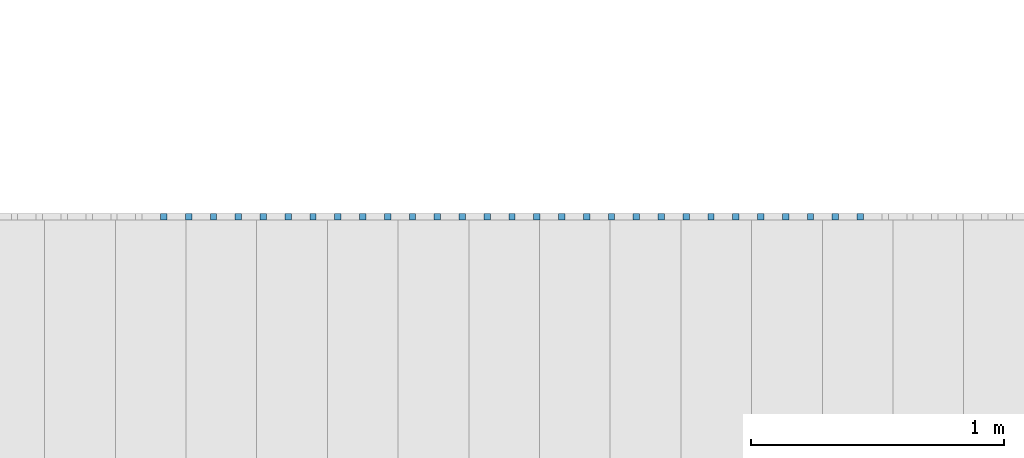
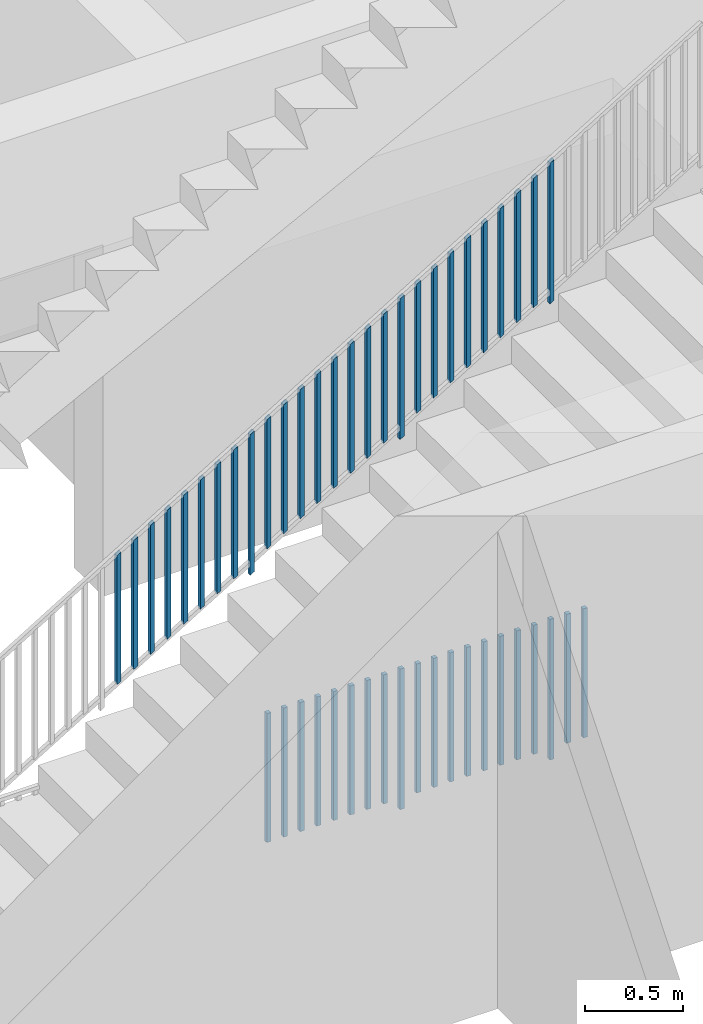
# One storey, part 21 of 23: 47 building element parts, 2 elements without a shape of their own.
"""IFC4 building model written with IfcOpenShell, lengths in metres."""

from ifc_helpers import new_model, entity, si_unit, converted_unit, derived_unit, direction, frame, origin_with_axes, place, context, subcontext, project, spatial, polygons, material, type_object, element, aggregate, save


model = new_model("IFC4")

# Units and contexts
model_context = context("Model", 3, precision=1e-05, world=origin_with_axes(), true_north=direction((0.0, 1.0)))
body_context = subcontext(model_context, "Body", "Model", "MODEL_VIEW")
ifc_project = project(units=[si_unit("LENGTHUNIT", "METRE"), si_unit("AREAUNIT", "SQUARE_METRE"), si_unit("VOLUMEUNIT", "CUBIC_METRE"), converted_unit("PLANEANGLEUNIT", "DEGREE", entity("IfcPlaneAngleMeasure", 0.0174532925199), si_unit("PLANEANGLEUNIT", "RADIAN"), dimensions=[0, 0, 0, 0, 0, 0, 0]), converted_unit("TIMEUNIT", "Year", entity("IfcTimeMeasure", 31556926.0), si_unit("TIMEUNIT", "SECOND"), dimensions=[0, 0, 1, 0, 0, 0, 0]), si_unit("MASSUNIT", "GRAM", prefix="KILO"), si_unit("THERMODYNAMICTEMPERATUREUNIT", "DEGREE_CELSIUS"), si_unit("LUMINOUSINTENSITYUNIT", "LUMEN"), si_unit("ENERGYUNIT", "JOULE", prefix="MEGA"), derived_unit("THERMALCONDUCTANCEUNIT", [(si_unit("POWERUNIT", "WATT"), 1), (si_unit("LENGTHUNIT", "METRE"), -1), (si_unit("THERMODYNAMICTEMPERATUREUNIT", "KELVIN"), -1)]), derived_unit("SPECIFICHEATCAPACITYUNIT", [(si_unit("ENERGYUNIT", "JOULE"), 1), (si_unit("MASSUNIT", "GRAM", prefix="KILO"), -1), (si_unit("THERMODYNAMICTEMPERATUREUNIT", "KELVIN"), -1)]), derived_unit("MASSDENSITYUNIT", [(si_unit("MASSUNIT", "GRAM", prefix="KILO"), 1), (si_unit("VOLUMEUNIT", "CUBIC_METRE"), -1)])], contexts=[model_context])

# Site, building, storey, space
site_placement = place(None, origin_with_axes())
site = spatial("IfcSite", under=ifc_project, at=site_placement, CompositionType="ELEMENT")
building_placement = place(site_placement, origin_with_axes())
building = spatial("IfcBuilding", under=site, at=building_placement, CompositionType="ELEMENT")
storey_placement = place(building_placement, origin_with_axes())
storey = spatial("IfcBuildingStorey", under=building, at=storey_placement, Name="0. Geschoss", CompositionType="ELEMENT", Elevation=0.0)
space_placement = place(storey_placement, frame((-11.4421993804, 1.37118776896, 0.0), z_axis=(0.0, 0.0, 1.0), x_axis=(0.0, -1.0, 0.0)))
space = spatial("IfcSpace", under=storey, at=space_placement, CompositionType="ELEMENT", PredefinedType="INTERNAL")

# Railing, building element parts
railing_type = type_object("IfcRailingType", PredefinedType="NOTDEFINED")
railing_1_placement = place(space_placement, frame((1.5, 8.0, 0.0), z_axis=(0.0, 0.0, 1.0), x_axis=(0.0, 1.0, 0.0)))
railing_1 = element("IfcRailing", 1, at=railing_1_placement, inside=space, type_object=railing_type, PredefinedType="NOTDEFINED")
ifc_material = material()
building_element_part_1_placement = place(railing_1_placement, origin_with_axes())
building_element_part_1 = element("IfcBuildingElementPart", 2, at=building_element_part_1_placement, material=ifc_material, PredefinedType="NOTDEFINED", context=body_context, shape_type="Tessellation", body=[
    polygons([(1.93101851852, -0.9125, 0.07), (1.93101851852, -0.8875, 0.07), (1.93101851852, -0.8875, 0.8775), (1.93101851852, -0.9125, 0.8775), (1.90601851852, -0.9125, 0.07), (1.90601851852, -0.8875, 0.07), (1.90601851852, -0.8875, 0.8775), (1.90601851852, -0.9125, 0.8775)], [[[1, 2, 3, 4]], [[1, 5, 6, 2]], [[2, 6, 7, 3]], [[4, 3, 7, 8]], [[5, 1, 4, 8]], [[6, 5, 8, 7]]], closed=True),
])
building_element_part_2_placement = place(railing_1_placement, origin_with_axes())
building_element_part_2 = element("IfcBuildingElementPart", 3, at=building_element_part_2_placement, material=ifc_material, PredefinedType="NOTDEFINED", context=body_context, shape_type="Tessellation", body=[
    polygons([(2.02953703704, -0.9125, 0.07), (2.02953703704, -0.8875, 0.07), (2.02953703704, -0.8875, 0.8775), (2.02953703704, -0.9125, 0.8775), (2.00453703704, -0.9125, 0.07), (2.00453703704, -0.8875, 0.07), (2.00453703704, -0.8875, 0.8775), (2.00453703704, -0.9125, 0.8775)], [[[1, 2, 3, 4]], [[1, 5, 6, 2]], [[2, 6, 7, 3]], [[4, 3, 7, 8]], [[5, 1, 4, 8]], [[6, 5, 8, 7]]], closed=True),
])
building_element_part_3_placement = place(railing_1_placement, origin_with_axes())
building_element_part_3 = element("IfcBuildingElementPart", 4, at=building_element_part_3_placement, material=ifc_material, PredefinedType="NOTDEFINED", context=body_context, shape_type="Tessellation", body=[
    polygons([(2.12805555556, -0.9125, 0.07), (2.12805555556, -0.8875, 0.07), (2.12805555556, -0.8875, 0.8775), (2.12805555556, -0.9125, 0.8775), (2.10305555556, -0.9125, 0.07), (2.10305555556, -0.8875, 0.07), (2.10305555556, -0.8875, 0.8775), (2.10305555556, -0.9125, 0.8775)], [[[1, 2, 3, 4]], [[1, 5, 6, 2]], [[2, 6, 7, 3]], [[4, 3, 7, 8]], [[5, 1, 4, 8]], [[6, 5, 8, 7]]], closed=True),
])
building_element_part_4_placement = place(railing_1_placement, origin_with_axes())
building_element_part_4 = element("IfcBuildingElementPart", 5, at=building_element_part_4_placement, material=ifc_material, PredefinedType="NOTDEFINED", context=body_context, shape_type="Tessellation", body=[
    polygons([(2.22657407407, -0.9125, 0.07), (2.22657407407, -0.8875, 0.07), (2.22657407407, -0.8875, 0.8775), (2.22657407407, -0.9125, 0.8775), (2.20157407407, -0.9125, 0.07), (2.20157407407, -0.8875, 0.07), (2.20157407407, -0.8875, 0.8775), (2.20157407407, -0.9125, 0.8775)], [[[1, 2, 3, 4]], [[1, 5, 6, 2]], [[2, 6, 7, 3]], [[4, 3, 7, 8]], [[5, 1, 4, 8]], [[6, 5, 8, 7]]], closed=True),
])
building_element_part_5_placement = place(railing_1_placement, origin_with_axes())
building_element_part_5 = element("IfcBuildingElementPart", 6, at=building_element_part_5_placement, material=ifc_material, PredefinedType="NOTDEFINED", context=body_context, shape_type="Tessellation", body=[
    polygons([(2.32509259259, -0.9125, 0.07), (2.32509259259, -0.8875, 0.07), (2.32509259259, -0.8875, 0.8775), (2.32509259259, -0.9125, 0.8775), (2.30009259259, -0.9125, 0.07), (2.30009259259, -0.8875, 0.07), (2.30009259259, -0.8875, 0.8775), (2.30009259259, -0.9125, 0.8775)], [[[1, 2, 3, 4]], [[1, 5, 6, 2]], [[2, 6, 7, 3]], [[4, 3, 7, 8]], [[5, 1, 4, 8]], [[6, 5, 8, 7]]], closed=True),
])
building_element_part_6_placement = place(railing_1_placement, origin_with_axes())
building_element_part_6 = element("IfcBuildingElementPart", 7, at=building_element_part_6_placement, material=ifc_material, PredefinedType="NOTDEFINED", context=body_context, shape_type="Tessellation", body=[
    polygons([(2.42361111111, -0.9125, 0.07), (2.42361111111, -0.8875, 0.07), (2.42361111111, -0.8875, 0.8775), (2.42361111111, -0.9125, 0.8775), (2.39861111111, -0.9125, 0.07), (2.39861111111, -0.8875, 0.07), (2.39861111111, -0.8875, 0.8775), (2.39861111111, -0.9125, 0.8775)], [[[1, 2, 3, 4]], [[1, 5, 6, 2]], [[2, 6, 7, 3]], [[4, 3, 7, 8]], [[5, 1, 4, 8]], [[6, 5, 8, 7]]], closed=True),
])
building_element_part_7_placement = place(railing_1_placement, origin_with_axes())
building_element_part_7 = element("IfcBuildingElementPart", 8, at=building_element_part_7_placement, material=ifc_material, PredefinedType="NOTDEFINED", context=body_context, shape_type="Tessellation", body=[
    polygons([(2.52212962963, -0.9125, 0.07), (2.52212962963, -0.8875, 0.07), (2.52212962963, -0.8875, 0.8775), (2.52212962963, -0.9125, 0.8775), (2.49712962963, -0.9125, 0.07), (2.49712962963, -0.8875, 0.07), (2.49712962963, -0.8875, 0.8775), (2.49712962963, -0.9125, 0.8775)], [[[1, 2, 3, 4]], [[1, 5, 6, 2]], [[2, 6, 7, 3]], [[4, 3, 7, 8]], [[5, 1, 4, 8]], [[6, 5, 8, 7]]], closed=True),
])
building_element_part_8_placement = place(railing_1_placement, origin_with_axes())
building_element_part_8 = element("IfcBuildingElementPart", 9, at=building_element_part_8_placement, material=ifc_material, PredefinedType="NOTDEFINED", context=body_context, shape_type="Tessellation", body=[
    polygons([(2.62064814815, -0.9125, 0.07), (2.62064814815, -0.8875, 0.07), (2.62064814815, -0.8875, 0.8775), (2.62064814815, -0.9125, 0.8775), (2.59564814815, -0.9125, 0.07), (2.59564814815, -0.8875, 0.07), (2.59564814815, -0.8875, 0.8775), (2.59564814815, -0.9125, 0.8775)], [[[1, 2, 3, 4]], [[1, 5, 6, 2]], [[2, 6, 7, 3]], [[4, 3, 7, 8]], [[5, 1, 4, 8]], [[6, 5, 8, 7]]], closed=True),
])
building_element_part_9_placement = place(railing_1_placement, origin_with_axes())
building_element_part_9 = element("IfcBuildingElementPart", 10, at=building_element_part_9_placement, material=ifc_material, PredefinedType="NOTDEFINED", context=body_context, shape_type="Tessellation", body=[
    polygons([(2.71916666667, -0.9125, 0.0), (2.71916666667, -0.8875, 0.0), (2.71916666667, -0.8875, 0.88), (2.71916666667, -0.9125, 0.88), (2.69416666667, -0.9125, 0.0), (2.69416666667, -0.8875, 0.0), (2.69416666667, -0.8875, 0.88), (2.69416666667, -0.9125, 0.88)], [[[1, 2, 3, 4]], [[1, 5, 6, 2]], [[2, 6, 7, 3]], [[4, 3, 7, 8]], [[5, 1, 4, 8]], [[6, 5, 8, 7]]], closed=True),
])
building_element_part_10_placement = place(railing_1_placement, origin_with_axes())
building_element_part_10 = element("IfcBuildingElementPart", 11, at=building_element_part_10_placement, material=ifc_material, PredefinedType="NOTDEFINED", context=body_context, shape_type="Tessellation", body=[
    polygons([(2.81768518519, -0.9125, 0.07), (2.81768518519, -0.8875, 0.07), (2.81768518519, -0.8875, 0.8775), (2.81768518519, -0.9125, 0.8775), (2.79268518519, -0.9125, 0.07), (2.79268518519, -0.8875, 0.07), (2.79268518519, -0.8875, 0.8775), (2.79268518519, -0.9125, 0.8775)], [[[1, 2, 3, 4]], [[1, 5, 6, 2]], [[2, 6, 7, 3]], [[4, 3, 7, 8]], [[5, 1, 4, 8]], [[6, 5, 8, 7]]], closed=True),
])
building_element_part_11_placement = place(railing_1_placement, origin_with_axes())
building_element_part_11 = element("IfcBuildingElementPart", 12, at=building_element_part_11_placement, material=ifc_material, PredefinedType="NOTDEFINED", context=body_context, shape_type="Tessellation", body=[
    polygons([(2.9162037037, -0.9125, 0.07), (2.9162037037, -0.8875, 0.07), (2.9162037037, -0.8875, 0.8775), (2.9162037037, -0.9125, 0.8775), (2.8912037037, -0.9125, 0.07), (2.8912037037, -0.8875, 0.07), (2.8912037037, -0.8875, 0.8775), (2.8912037037, -0.9125, 0.8775)], [[[1, 2, 3, 4]], [[1, 5, 6, 2]], [[2, 6, 7, 3]], [[4, 3, 7, 8]], [[5, 1, 4, 8]], [[6, 5, 8, 7]]], closed=True),
])
building_element_part_12_placement = place(railing_1_placement, origin_with_axes())
building_element_part_12 = element("IfcBuildingElementPart", 13, at=building_element_part_12_placement, material=ifc_material, PredefinedType="NOTDEFINED", context=body_context, shape_type="Tessellation", body=[
    polygons([(3.01472222222, -0.9125, 0.07), (3.01472222222, -0.8875, 0.07), (3.01472222222, -0.8875, 0.8775), (3.01472222222, -0.9125, 0.8775), (2.98972222222, -0.9125, 0.07), (2.98972222222, -0.8875, 0.07), (2.98972222222, -0.8875, 0.8775), (2.98972222222, -0.9125, 0.8775)], [[[1, 2, 3, 4]], [[1, 5, 6, 2]], [[2, 6, 7, 3]], [[4, 3, 7, 8]], [[5, 1, 4, 8]], [[6, 5, 8, 7]]], closed=True),
])
building_element_part_13_placement = place(railing_1_placement, origin_with_axes())
building_element_part_13 = element("IfcBuildingElementPart", 14, at=building_element_part_13_placement, material=ifc_material, PredefinedType="NOTDEFINED", context=body_context, shape_type="Tessellation", body=[
    polygons([(3.11324074074, -0.9125, 0.07), (3.11324074074, -0.8875, 0.07), (3.11324074074, -0.8875, 0.8775), (3.11324074074, -0.9125, 0.8775), (3.08824074074, -0.9125, 0.07), (3.08824074074, -0.8875, 0.07), (3.08824074074, -0.8875, 0.8775), (3.08824074074, -0.9125, 0.8775)], [[[1, 2, 3, 4]], [[1, 5, 6, 2]], [[2, 6, 7, 3]], [[4, 3, 7, 8]], [[5, 1, 4, 8]], [[6, 5, 8, 7]]], closed=True),
])
building_element_part_14_placement = place(railing_1_placement, origin_with_axes())
building_element_part_14 = element("IfcBuildingElementPart", 15, at=building_element_part_14_placement, material=ifc_material, PredefinedType="NOTDEFINED", context=body_context, shape_type="Tessellation", body=[
    polygons([(3.21175925926, -0.9125, 0.07), (3.21175925926, -0.8875, 0.07), (3.21175925926, -0.8875, 0.8775), (3.21175925926, -0.9125, 0.8775), (3.18675925926, -0.9125, 0.07), (3.18675925926, -0.8875, 0.07), (3.18675925926, -0.8875, 0.8775), (3.18675925926, -0.9125, 0.8775)], [[[1, 2, 3, 4]], [[1, 5, 6, 2]], [[2, 6, 7, 3]], [[4, 3, 7, 8]], [[5, 1, 4, 8]], [[6, 5, 8, 7]]], closed=True),
])
building_element_part_15_placement = place(railing_1_placement, origin_with_axes())
building_element_part_15 = element("IfcBuildingElementPart", 16, at=building_element_part_15_placement, material=ifc_material, PredefinedType="NOTDEFINED", context=body_context, shape_type="Tessellation", body=[
    polygons([(3.31027777778, -0.9125, 0.07), (3.31027777778, -0.8875, 0.07), (3.31027777778, -0.8875, 0.8775), (3.31027777778, -0.9125, 0.8775), (3.28527777778, -0.9125, 0.07), (3.28527777778, -0.8875, 0.07), (3.28527777778, -0.8875, 0.8775), (3.28527777778, -0.9125, 0.8775)], [[[1, 2, 3, 4]], [[1, 5, 6, 2]], [[2, 6, 7, 3]], [[4, 3, 7, 8]], [[5, 1, 4, 8]], [[6, 5, 8, 7]]], closed=True),
])
building_element_part_16_placement = place(railing_1_placement, origin_with_axes())
building_element_part_16 = element("IfcBuildingElementPart", 17, at=building_element_part_16_placement, material=ifc_material, PredefinedType="NOTDEFINED", context=body_context, shape_type="Tessellation", body=[
    polygons([(3.4087962963, -0.9125, 0.07), (3.4087962963, -0.8875, 0.07), (3.4087962963, -0.8875, 0.8775), (3.4087962963, -0.9125, 0.8775), (3.3837962963, -0.9125, 0.07), (3.3837962963, -0.8875, 0.07), (3.3837962963, -0.8875, 0.8775), (3.3837962963, -0.9125, 0.8775)], [[[1, 2, 3, 4]], [[1, 5, 6, 2]], [[2, 6, 7, 3]], [[4, 3, 7, 8]], [[5, 1, 4, 8]], [[6, 5, 8, 7]]], closed=True),
])
building_element_part_17_placement = place(railing_1_placement, origin_with_axes())
building_element_part_17 = element("IfcBuildingElementPart", 18, at=building_element_part_17_placement, material=ifc_material, PredefinedType="NOTDEFINED", context=body_context, shape_type="Tessellation", body=[
    polygons([(3.50731481481, -0.9125, 0.07), (3.50731481481, -0.8875, 0.07), (3.50731481481, -0.8875, 0.8775), (3.50731481481, -0.9125, 0.8775), (3.48231481481, -0.9125, 0.07), (3.48231481481, -0.8875, 0.07), (3.48231481481, -0.8875, 0.8775), (3.48231481481, -0.9125, 0.8775)], [[[1, 2, 3, 4]], [[1, 5, 6, 2]], [[2, 6, 7, 3]], [[4, 3, 7, 8]], [[5, 1, 4, 8]], [[6, 5, 8, 7]]], closed=True),
])
building_element_part_18_placement = place(railing_1_placement, origin_with_axes())
building_element_part_18 = element("IfcBuildingElementPart", 19, at=building_element_part_18_placement, material=ifc_material, PredefinedType="NOTDEFINED", context=body_context, shape_type="Tessellation", body=[
    polygons([(3.60583333333, -0.9125, 0.0), (3.60583333333, -0.8875, 0.0), (3.60583333333, -0.8875, 0.88), (3.60583333333, -0.9125, 0.88), (3.58083333333, -0.9125, 0.0), (3.58083333333, -0.8875, 0.0), (3.58083333333, -0.8875, 0.88), (3.58083333333, -0.9125, 0.88)], [[[1, 2, 3, 4]], [[1, 5, 6, 2]], [[2, 6, 7, 3]], [[4, 3, 7, 8]], [[5, 1, 4, 8]], [[6, 5, 8, 7]]], closed=True),
])
building_element_part_19_placement = place(railing_1_placement, origin_with_axes())
building_element_part_19 = element("IfcBuildingElementPart", 20, at=building_element_part_19_placement, material=ifc_material, PredefinedType="NOTDEFINED", context=body_context, shape_type="Tessellation", body=[
    polygons([(3.70435185185, -0.9125, 0.07), (3.70435185185, -0.8875, 0.07), (3.70435185185, -0.8875, 0.8775), (3.70435185185, -0.9125, 0.8775), (3.67935185185, -0.9125, 0.07), (3.67935185185, -0.8875, 0.07), (3.67935185185, -0.8875, 0.8775), (3.67935185185, -0.9125, 0.8775)], [[[1, 2, 3, 4]], [[1, 5, 6, 2]], [[2, 6, 7, 3]], [[4, 3, 7, 8]], [[5, 1, 4, 8]], [[6, 5, 8, 7]]], closed=True),
])
building_element_part_20_placement = place(railing_1_placement, origin_with_axes())
building_element_part_20 = element("IfcBuildingElementPart", 21, at=building_element_part_20_placement, material=ifc_material, PredefinedType="NOTDEFINED", context=body_context, shape_type="Tessellation", body=[
    polygons([(3.80287037037, -0.9125, 0.07), (3.80287037037, -0.8875, 0.07), (3.80287037037, -0.8875, 0.8775), (3.80287037037, -0.9125, 0.8775), (3.77787037037, -0.9125, 0.07), (3.77787037037, -0.8875, 0.07), (3.77787037037, -0.8875, 0.8775), (3.77787037037, -0.9125, 0.8775)], [[[1, 2, 3, 4]], [[1, 5, 6, 2]], [[2, 6, 7, 3]], [[4, 3, 7, 8]], [[5, 1, 4, 8]], [[6, 5, 8, 7]]], closed=True),
])
aggregate(railing_1, [building_element_part_1, building_element_part_2, building_element_part_3, building_element_part_4, building_element_part_5, building_element_part_6, building_element_part_7, building_element_part_8, building_element_part_9, building_element_part_10, building_element_part_11, building_element_part_12, building_element_part_13, building_element_part_14, building_element_part_15, building_element_part_16, building_element_part_17, building_element_part_18, building_element_part_19, building_element_part_20])

railing_2_placement = place(space_placement, frame((2.4, 7.16, 0.17), z_axis=(0.0, 0.0, 1.0), x_axis=(0.0, 1.0, 0.0)))
railing_2 = element("IfcRailing", 22, at=railing_2_placement, inside=space, type_object=railing_type, PredefinedType="NOTDEFINED")
building_element_part_21_placement = place(railing_2_placement, origin_with_axes())
building_element_part_21 = element("IfcBuildingElementPart", 23, at=building_element_part_21_placement, material=ifc_material, PredefinedType="NOTDEFINED", context=body_context, shape_type="Tessellation", body=[
    polygons([(1.88435185185, -0.0125, 1.2140707672), (1.88435185185, 0.0125, 1.2140707672), (1.88435185185, 0.0125, 2.0215707672), (1.88435185185, -0.0125, 2.0215707672), (1.85935185185, -0.0125, 1.19889219577), (1.85935185185, 0.0125, 1.19889219577), (1.85935185185, 0.0125, 2.00639219577), (1.85935185185, -0.0125, 2.00639219577)], [[[1, 2, 3, 4]], [[1, 5, 6, 2]], [[2, 6, 7, 3]], [[4, 3, 7, 8]], [[5, 1, 4, 8]], [[6, 5, 8, 7]]], closed=True),
])
building_element_part_22_placement = place(railing_2_placement, origin_with_axes())
building_element_part_22 = element("IfcBuildingElementPart", 24, at=building_element_part_22_placement, material=ifc_material, PredefinedType="NOTDEFINED", context=body_context, shape_type="Tessellation", body=[
    polygons([(1.98287037037, -0.0125, 1.27388558201), (1.98287037037, 0.0125, 1.27388558201), (1.98287037037, 0.0125, 2.08138558201), (1.98287037037, -0.0125, 2.08138558201), (1.95787037037, -0.0125, 1.25870701058), (1.95787037037, 0.0125, 1.25870701058), (1.95787037037, 0.0125, 2.06620701058), (1.95787037037, -0.0125, 2.06620701058)], [[[1, 2, 3, 4]], [[1, 5, 6, 2]], [[2, 6, 7, 3]], [[4, 3, 7, 8]], [[5, 1, 4, 8]], [[6, 5, 8, 7]]], closed=True),
])
building_element_part_23_placement = place(railing_2_placement, origin_with_axes())
building_element_part_23 = element("IfcBuildingElementPart", 25, at=building_element_part_23_placement, material=ifc_material, PredefinedType="NOTDEFINED", context=body_context, shape_type="Tessellation", body=[
    polygons([(2.08138888889, -0.0125, 1.33370039683), (2.08138888889, 0.0125, 1.33370039683), (2.08138888889, 0.0125, 2.14120039683), (2.08138888889, -0.0125, 2.14120039683), (2.05638888889, -0.0125, 1.3185218254), (2.05638888889, 0.0125, 1.3185218254), (2.05638888889, 0.0125, 2.1260218254), (2.05638888889, -0.0125, 2.1260218254)], [[[1, 2, 3, 4]], [[1, 5, 6, 2]], [[2, 6, 7, 3]], [[4, 3, 7, 8]], [[5, 1, 4, 8]], [[6, 5, 8, 7]]], closed=True),
])
building_element_part_24_placement = place(railing_2_placement, origin_with_axes())
building_element_part_24 = element("IfcBuildingElementPart", 26, at=building_element_part_24_placement, material=ifc_material, PredefinedType="NOTDEFINED", context=body_context, shape_type="Tessellation", body=[
    polygons([(2.17990740741, -0.0125, 1.39351521164), (2.17990740741, 0.0125, 1.39351521164), (2.17990740741, 0.0125, 2.20101521164), (2.17990740741, -0.0125, 2.20101521164), (2.15490740741, -0.0125, 1.37833664021), (2.15490740741, 0.0125, 1.37833664021), (2.15490740741, 0.0125, 2.18583664021), (2.15490740741, -0.0125, 2.18583664021)], [[[1, 2, 3, 4]], [[1, 5, 6, 2]], [[2, 6, 7, 3]], [[4, 3, 7, 8]], [[5, 1, 4, 8]], [[6, 5, 8, 7]]], closed=True),
])
building_element_part_25_placement = place(railing_2_placement, origin_with_axes())
building_element_part_25 = element("IfcBuildingElementPart", 27, at=building_element_part_25_placement, material=ifc_material, PredefinedType="NOTDEFINED", context=body_context, shape_type="Tessellation", body=[
    polygons([(2.27842592593, -0.0125, 1.45333002646), (2.27842592593, 0.0125, 1.45333002646), (2.27842592593, 0.0125, 2.26083002646), (2.27842592593, -0.0125, 2.26083002646), (2.25342592593, -0.0125, 1.43815145503), (2.25342592593, 0.0125, 1.43815145503), (2.25342592593, 0.0125, 2.24565145503), (2.25342592593, -0.0125, 2.24565145503)], [[[1, 2, 3, 4]], [[1, 5, 6, 2]], [[2, 6, 7, 3]], [[4, 3, 7, 8]], [[5, 1, 4, 8]], [[6, 5, 8, 7]]], closed=True),
])
building_element_part_26_placement = place(railing_2_placement, origin_with_axes())
building_element_part_26 = element("IfcBuildingElementPart", 28, at=building_element_part_26_placement, material=ifc_material, PredefinedType="NOTDEFINED", context=body_context, shape_type="Tessellation", body=[
    polygons([(2.37694444444, -0.0125, 1.51314484127), (2.37694444444, 0.0125, 1.51314484127), (2.37694444444, 0.0125, 2.32064484127), (2.37694444444, -0.0125, 2.32064484127), (2.35194444444, -0.0125, 1.49796626984), (2.35194444444, 0.0125, 1.49796626984), (2.35194444444, 0.0125, 2.30546626984), (2.35194444444, -0.0125, 2.30546626984)], [[[1, 2, 3, 4]], [[1, 5, 6, 2]], [[2, 6, 7, 3]], [[4, 3, 7, 8]], [[5, 1, 4, 8]], [[6, 5, 8, 7]]], closed=True),
])
building_element_part_27_placement = place(railing_2_placement, origin_with_axes())
building_element_part_27 = element("IfcBuildingElementPart", 29, at=building_element_part_27_placement, material=ifc_material, PredefinedType="NOTDEFINED", context=body_context, shape_type="Tessellation", body=[
    polygons([(2.47546296296, -0.0125, 1.57295965608), (2.47546296296, 0.0125, 1.57295965608), (2.47546296296, 0.0125, 2.38045965608), (2.47546296296, -0.0125, 2.38045965608), (2.45046296296, -0.0125, 1.55778108466), (2.45046296296, 0.0125, 1.55778108466), (2.45046296296, 0.0125, 2.36528108466), (2.45046296296, -0.0125, 2.36528108466)], [[[1, 2, 3, 4]], [[1, 5, 6, 2]], [[2, 6, 7, 3]], [[4, 3, 7, 8]], [[5, 1, 4, 8]], [[6, 5, 8, 7]]], closed=True),
])
building_element_part_28_placement = place(railing_2_placement, origin_with_axes())
building_element_part_28 = element("IfcBuildingElementPart", 30, at=building_element_part_28_placement, material=ifc_material, PredefinedType="NOTDEFINED", context=body_context, shape_type="Tessellation", body=[
    polygons([(2.57398148148, -0.0125, 1.6327744709), (2.57398148148, 0.0125, 1.6327744709), (2.57398148148, 0.0125, 2.4402744709), (2.57398148148, -0.0125, 2.4402744709), (2.54898148148, -0.0125, 1.61759589947), (2.54898148148, 0.0125, 1.61759589947), (2.54898148148, 0.0125, 2.42509589947), (2.54898148148, -0.0125, 2.42509589947)], [[[1, 2, 3, 4]], [[1, 5, 6, 2]], [[2, 6, 7, 3]], [[4, 3, 7, 8]], [[5, 1, 4, 8]], [[6, 5, 8, 7]]], closed=True),
])
building_element_part_29_placement = place(railing_2_placement, origin_with_axes())
building_element_part_29 = element("IfcBuildingElementPart", 31, at=building_element_part_29_placement, material=ifc_material, PredefinedType="NOTDEFINED", context=body_context, shape_type="Tessellation", body=[
    polygons([(2.6725, -0.0125, 1.62258928571), (2.6725, 0.0125, 1.62258928571), (2.6725, 0.0125, 2.50258928571), (2.6725, -0.0125, 2.50258928571), (2.6475, -0.0125, 1.60741071429), (2.6475, 0.0125, 1.60741071429), (2.6475, 0.0125, 2.48741071429), (2.6475, -0.0125, 2.48741071429)], [[[1, 2, 3, 4]], [[1, 5, 6, 2]], [[2, 6, 7, 3]], [[4, 3, 7, 8]], [[5, 1, 4, 8]], [[6, 5, 8, 7]]], closed=True),
])
building_element_part_30_placement = place(railing_2_placement, origin_with_axes())
building_element_part_30 = element("IfcBuildingElementPart", 32, at=building_element_part_30_placement, material=ifc_material, PredefinedType="NOTDEFINED", context=body_context, shape_type="Tessellation", body=[
    polygons([(2.77101851852, -0.0125, 1.75240410053), (2.77101851852, 0.0125, 1.75240410053), (2.77101851852, 0.0125, 2.55990410053), (2.77101851852, -0.0125, 2.55990410053), (2.74601851852, -0.0125, 1.7372255291), (2.74601851852, 0.0125, 1.7372255291), (2.74601851852, 0.0125, 2.5447255291), (2.74601851852, -0.0125, 2.5447255291)], [[[1, 2, 3, 4]], [[1, 5, 6, 2]], [[2, 6, 7, 3]], [[4, 3, 7, 8]], [[5, 1, 4, 8]], [[6, 5, 8, 7]]], closed=True),
])
building_element_part_31_placement = place(railing_2_placement, origin_with_axes())
building_element_part_31 = element("IfcBuildingElementPart", 33, at=building_element_part_31_placement, material=ifc_material, PredefinedType="NOTDEFINED", context=body_context, shape_type="Tessellation", body=[
    polygons([(2.86953703704, -0.0125, 1.81221891534), (2.86953703704, 0.0125, 1.81221891534), (2.86953703704, 0.0125, 2.61971891534), (2.86953703704, -0.0125, 2.61971891534), (2.84453703704, -0.0125, 1.79704034392), (2.84453703704, 0.0125, 1.79704034392), (2.84453703704, 0.0125, 2.60454034392), (2.84453703704, -0.0125, 2.60454034392)], [[[1, 2, 3, 4]], [[1, 5, 6, 2]], [[2, 6, 7, 3]], [[4, 3, 7, 8]], [[5, 1, 4, 8]], [[6, 5, 8, 7]]], closed=True),
])
building_element_part_32_placement = place(railing_2_placement, origin_with_axes())
building_element_part_32 = element("IfcBuildingElementPart", 34, at=building_element_part_32_placement, material=ifc_material, PredefinedType="NOTDEFINED", context=body_context, shape_type="Tessellation", body=[
    polygons([(2.96805555556, -0.0125, 1.87203373016), (2.96805555556, 0.0125, 1.87203373016), (2.96805555556, 0.0125, 2.67953373016), (2.96805555556, -0.0125, 2.67953373016), (2.94305555556, -0.0125, 1.85685515873), (2.94305555556, 0.0125, 1.85685515873), (2.94305555556, 0.0125, 2.66435515873), (2.94305555556, -0.0125, 2.66435515873)], [[[1, 2, 3, 4]], [[1, 5, 6, 2]], [[2, 6, 7, 3]], [[4, 3, 7, 8]], [[5, 1, 4, 8]], [[6, 5, 8, 7]]], closed=True),
])
building_element_part_33_placement = place(railing_2_placement, origin_with_axes())
building_element_part_33 = element("IfcBuildingElementPart", 35, at=building_element_part_33_placement, material=ifc_material, PredefinedType="NOTDEFINED", context=body_context, shape_type="Tessellation", body=[
    polygons([(3.06657407407, -0.0125, 1.93184854497), (3.06657407407, 0.0125, 1.93184854497), (3.06657407407, 0.0125, 2.73934854497), (3.06657407407, -0.0125, 2.73934854497), (3.04157407407, -0.0125, 1.91666997354), (3.04157407407, 0.0125, 1.91666997354), (3.04157407407, 0.0125, 2.72416997354), (3.04157407407, -0.0125, 2.72416997354)], [[[1, 2, 3, 4]], [[1, 5, 6, 2]], [[2, 6, 7, 3]], [[4, 3, 7, 8]], [[5, 1, 4, 8]], [[6, 5, 8, 7]]], closed=True),
])
building_element_part_34_placement = place(railing_2_placement, origin_with_axes())
building_element_part_34 = element("IfcBuildingElementPart", 36, at=building_element_part_34_placement, material=ifc_material, PredefinedType="NOTDEFINED", context=body_context, shape_type="Tessellation", body=[
    polygons([(3.16509259259, -0.0125, 1.99166335979), (3.16509259259, 0.0125, 1.99166335979), (3.16509259259, 0.0125, 2.79916335979), (3.16509259259, -0.0125, 2.79916335979), (3.14009259259, -0.0125, 1.97648478836), (3.14009259259, 0.0125, 1.97648478836), (3.14009259259, 0.0125, 2.78398478836), (3.14009259259, -0.0125, 2.78398478836)], [[[1, 2, 3, 4]], [[1, 5, 6, 2]], [[2, 6, 7, 3]], [[4, 3, 7, 8]], [[5, 1, 4, 8]], [[6, 5, 8, 7]]], closed=True),
])
building_element_part_35_placement = place(railing_2_placement, origin_with_axes())
building_element_part_35 = element("IfcBuildingElementPart", 37, at=building_element_part_35_placement, material=ifc_material, PredefinedType="NOTDEFINED", context=body_context, shape_type="Tessellation", body=[
    polygons([(3.26361111111, -0.0125, 2.0514781746), (3.26361111111, 0.0125, 2.0514781746), (3.26361111111, 0.0125, 2.8589781746), (3.26361111111, -0.0125, 2.8589781746), (3.23861111111, -0.0125, 2.03629960317), (3.23861111111, 0.0125, 2.03629960317), (3.23861111111, 0.0125, 2.84379960317), (3.23861111111, -0.0125, 2.84379960317)], [[[1, 2, 3, 4]], [[1, 5, 6, 2]], [[2, 6, 7, 3]], [[4, 3, 7, 8]], [[5, 1, 4, 8]], [[6, 5, 8, 7]]], closed=True),
])
building_element_part_36_placement = place(railing_2_placement, origin_with_axes())
building_element_part_36 = element("IfcBuildingElementPart", 38, at=building_element_part_36_placement, material=ifc_material, PredefinedType="NOTDEFINED", context=body_context, shape_type="Tessellation", body=[
    polygons([(3.36212962963, -0.0125, 2.11129298942), (3.36212962963, 0.0125, 2.11129298942), (3.36212962963, 0.0125, 2.91879298942), (3.36212962963, -0.0125, 2.91879298942), (3.33712962963, -0.0125, 2.09611441799), (3.33712962963, 0.0125, 2.09611441799), (3.33712962963, 0.0125, 2.90361441799), (3.33712962963, -0.0125, 2.90361441799)], [[[1, 2, 3, 4]], [[1, 5, 6, 2]], [[2, 6, 7, 3]], [[4, 3, 7, 8]], [[5, 1, 4, 8]], [[6, 5, 8, 7]]], closed=True),
])
building_element_part_37_placement = place(railing_2_placement, origin_with_axes())
building_element_part_37 = element("IfcBuildingElementPart", 39, at=building_element_part_37_placement, material=ifc_material, PredefinedType="NOTDEFINED", context=body_context, shape_type="Tessellation", body=[
    polygons([(3.46064814815, -0.0125, 2.17110780423), (3.46064814815, 0.0125, 2.17110780423), (3.46064814815, 0.0125, 2.97860780423), (3.46064814815, -0.0125, 2.97860780423), (3.43564814815, -0.0125, 2.1559292328), (3.43564814815, 0.0125, 2.1559292328), (3.43564814815, 0.0125, 2.9634292328), (3.43564814815, -0.0125, 2.9634292328)], [[[1, 2, 3, 4]], [[1, 5, 6, 2]], [[2, 6, 7, 3]], [[4, 3, 7, 8]], [[5, 1, 4, 8]], [[6, 5, 8, 7]]], closed=True),
])
building_element_part_38_placement = place(railing_2_placement, origin_with_axes())
building_element_part_38 = element("IfcBuildingElementPart", 40, at=building_element_part_38_placement, material=ifc_material, PredefinedType="NOTDEFINED", context=body_context, shape_type="Tessellation", body=[
    polygons([(3.55916666667, -0.0125, 2.16092261905), (3.55916666667, 0.0125, 2.16092261905), (3.55916666667, 0.0125, 3.04092261905), (3.55916666667, -0.0125, 3.04092261905), (3.53416666667, -0.0125, 2.14574404762), (3.53416666667, 0.0125, 2.14574404762), (3.53416666667, 0.0125, 3.02574404762), (3.53416666667, -0.0125, 3.02574404762)], [[[1, 2, 3, 4]], [[1, 5, 6, 2]], [[2, 6, 7, 3]], [[4, 3, 7, 8]], [[5, 1, 4, 8]], [[6, 5, 8, 7]]], closed=True),
])
building_element_part_39_placement = place(railing_2_placement, origin_with_axes())
building_element_part_39 = element("IfcBuildingElementPart", 41, at=building_element_part_39_placement, material=ifc_material, PredefinedType="NOTDEFINED", context=body_context, shape_type="Tessellation", body=[
    polygons([(3.65768518519, -0.0125, 2.29073743386), (3.65768518519, 0.0125, 2.29073743386), (3.65768518519, 0.0125, 3.09823743386), (3.65768518519, -0.0125, 3.09823743386), (3.63268518519, -0.0125, 2.27555886243), (3.63268518519, 0.0125, 2.27555886243), (3.63268518519, 0.0125, 3.08305886243), (3.63268518519, -0.0125, 3.08305886243)], [[[1, 2, 3, 4]], [[1, 5, 6, 2]], [[2, 6, 7, 3]], [[4, 3, 7, 8]], [[5, 1, 4, 8]], [[6, 5, 8, 7]]], closed=True),
])
building_element_part_40_placement = place(railing_2_placement, origin_with_axes())
building_element_part_40 = element("IfcBuildingElementPart", 42, at=building_element_part_40_placement, material=ifc_material, PredefinedType="NOTDEFINED", context=body_context, shape_type="Tessellation", body=[
    polygons([(3.7562037037, -0.0125, 2.35055224868), (3.7562037037, 0.0125, 2.35055224868), (3.7562037037, 0.0125, 3.15805224868), (3.7562037037, -0.0125, 3.15805224868), (3.7312037037, -0.0125, 2.33537367725), (3.7312037037, 0.0125, 2.33537367725), (3.7312037037, 0.0125, 3.14287367725), (3.7312037037, -0.0125, 3.14287367725)], [[[1, 2, 3, 4]], [[1, 5, 6, 2]], [[2, 6, 7, 3]], [[4, 3, 7, 8]], [[5, 1, 4, 8]], [[6, 5, 8, 7]]], closed=True),
])
building_element_part_41_placement = place(railing_2_placement, origin_with_axes())
building_element_part_41 = element("IfcBuildingElementPart", 43, at=building_element_part_41_placement, material=ifc_material, PredefinedType="NOTDEFINED", context=body_context, shape_type="Tessellation", body=[
    polygons([(3.85472222222, -0.0125, 2.41036706349), (3.85472222222, 0.0125, 2.41036706349), (3.85472222222, 0.0125, 3.21786706349), (3.85472222222, -0.0125, 3.21786706349), (3.82972222222, -0.0125, 2.39518849206), (3.82972222222, 0.0125, 2.39518849206), (3.82972222222, 0.0125, 3.20268849206), (3.82972222222, -0.0125, 3.20268849206)], [[[1, 2, 3, 4]], [[1, 5, 6, 2]], [[2, 6, 7, 3]], [[4, 3, 7, 8]], [[5, 1, 4, 8]], [[6, 5, 8, 7]]], closed=True),
])
building_element_part_42_placement = place(railing_2_placement, origin_with_axes())
building_element_part_42 = element("IfcBuildingElementPart", 44, at=building_element_part_42_placement, material=ifc_material, PredefinedType="NOTDEFINED", context=body_context, shape_type="Tessellation", body=[
    polygons([(3.95324074074, -0.0125, 2.47018187831), (3.95324074074, 0.0125, 2.47018187831), (3.95324074074, 0.0125, 3.27768187831), (3.95324074074, -0.0125, 3.27768187831), (3.92824074074, -0.0125, 2.45500330688), (3.92824074074, 0.0125, 2.45500330688), (3.92824074074, 0.0125, 3.26250330688), (3.92824074074, -0.0125, 3.26250330688)], [[[1, 2, 3, 4]], [[1, 5, 6, 2]], [[2, 6, 7, 3]], [[4, 3, 7, 8]], [[5, 1, 4, 8]], [[6, 5, 8, 7]]], closed=True),
])
building_element_part_43_placement = place(railing_2_placement, origin_with_axes())
building_element_part_43 = element("IfcBuildingElementPart", 45, at=building_element_part_43_placement, material=ifc_material, PredefinedType="NOTDEFINED", context=body_context, shape_type="Tessellation", body=[
    polygons([(4.05175925926, -0.0125, 2.52999669312), (4.05175925926, 0.0125, 2.52999669312), (4.05175925926, 0.0125, 3.33749669312), (4.05175925926, -0.0125, 3.33749669312), (4.02675925926, -0.0125, 2.51481812169), (4.02675925926, 0.0125, 2.51481812169), (4.02675925926, 0.0125, 3.32231812169), (4.02675925926, -0.0125, 3.32231812169)], [[[1, 2, 3, 4]], [[1, 5, 6, 2]], [[2, 6, 7, 3]], [[4, 3, 7, 8]], [[5, 1, 4, 8]], [[6, 5, 8, 7]]], closed=True),
])
building_element_part_44_placement = place(railing_2_placement, origin_with_axes())
building_element_part_44 = element("IfcBuildingElementPart", 46, at=building_element_part_44_placement, material=ifc_material, PredefinedType="NOTDEFINED", context=body_context, shape_type="Tessellation", body=[
    polygons([(4.15027777778, -0.0125, 2.58981150794), (4.15027777778, 0.0125, 2.58981150794), (4.15027777778, 0.0125, 3.39731150794), (4.15027777778, -0.0125, 3.39731150794), (4.12527777778, -0.0125, 2.57463293651), (4.12527777778, 0.0125, 2.57463293651), (4.12527777778, 0.0125, 3.38213293651), (4.12527777778, -0.0125, 3.38213293651)], [[[1, 2, 3, 4]], [[1, 5, 6, 2]], [[2, 6, 7, 3]], [[4, 3, 7, 8]], [[5, 1, 4, 8]], [[6, 5, 8, 7]]], closed=True),
])
building_element_part_45_placement = place(railing_2_placement, origin_with_axes())
building_element_part_45 = element("IfcBuildingElementPart", 47, at=building_element_part_45_placement, material=ifc_material, PredefinedType="NOTDEFINED", context=body_context, shape_type="Tessellation", body=[
    polygons([(4.2487962963, -0.0125, 2.64962632275), (4.2487962963, 0.0125, 2.64962632275), (4.2487962963, 0.0125, 3.45712632275), (4.2487962963, -0.0125, 3.45712632275), (4.2237962963, -0.0125, 2.63444775132), (4.2237962963, 0.0125, 2.63444775132), (4.2237962963, 0.0125, 3.44194775132), (4.2237962963, -0.0125, 3.44194775132)], [[[1, 2, 3, 4]], [[1, 5, 6, 2]], [[2, 6, 7, 3]], [[4, 3, 7, 8]], [[5, 1, 4, 8]], [[6, 5, 8, 7]]], closed=True),
])
building_element_part_46_placement = place(railing_2_placement, origin_with_axes())
building_element_part_46 = element("IfcBuildingElementPart", 48, at=building_element_part_46_placement, material=ifc_material, PredefinedType="NOTDEFINED", context=body_context, shape_type="Tessellation", body=[
    polygons([(4.34731481481, -0.0125, 2.70944113757), (4.34731481481, 0.0125, 2.70944113757), (4.34731481481, 0.0125, 3.51694113757), (4.34731481481, -0.0125, 3.51694113757), (4.32231481481, -0.0125, 2.69426256614), (4.32231481481, 0.0125, 2.69426256614), (4.32231481481, 0.0125, 3.50176256614), (4.32231481481, -0.0125, 3.50176256614)], [[[1, 2, 3, 4]], [[1, 5, 6, 2]], [[2, 6, 7, 3]], [[4, 3, 7, 8]], [[5, 1, 4, 8]], [[6, 5, 8, 7]]], closed=True),
])
building_element_part_47_placement = place(railing_2_placement, origin_with_axes())
building_element_part_47 = element("IfcBuildingElementPart", 49, at=building_element_part_47_placement, material=ifc_material, PredefinedType="NOTDEFINED", context=body_context, shape_type="Tessellation", body=[
    polygons([(4.44583333333, -0.0125, 2.69925595238), (4.44583333333, 0.0125, 2.69925595238), (4.44583333333, 0.0125, 3.57925595238), (4.44583333333, -0.0125, 3.57925595238), (4.42083333333, -0.0125, 2.68407738095), (4.42083333333, 0.0125, 2.68407738095), (4.42083333333, 0.0125, 3.56407738095), (4.42083333333, -0.0125, 3.56407738095)], [[[1, 2, 3, 4]], [[1, 5, 6, 2]], [[2, 6, 7, 3]], [[4, 3, 7, 8]], [[5, 1, 4, 8]], [[6, 5, 8, 7]]], closed=True),
])
aggregate(railing_2, [building_element_part_21, building_element_part_22, building_element_part_23, building_element_part_24, building_element_part_25, building_element_part_26, building_element_part_27, building_element_part_28, building_element_part_29, building_element_part_30, building_element_part_31, building_element_part_32, building_element_part_33, building_element_part_34, building_element_part_35, building_element_part_36, building_element_part_37, building_element_part_38, building_element_part_39, building_element_part_40, building_element_part_41, building_element_part_42, building_element_part_43, building_element_part_44, building_element_part_45, building_element_part_46, building_element_part_47])

save(model, "model.ifc")
